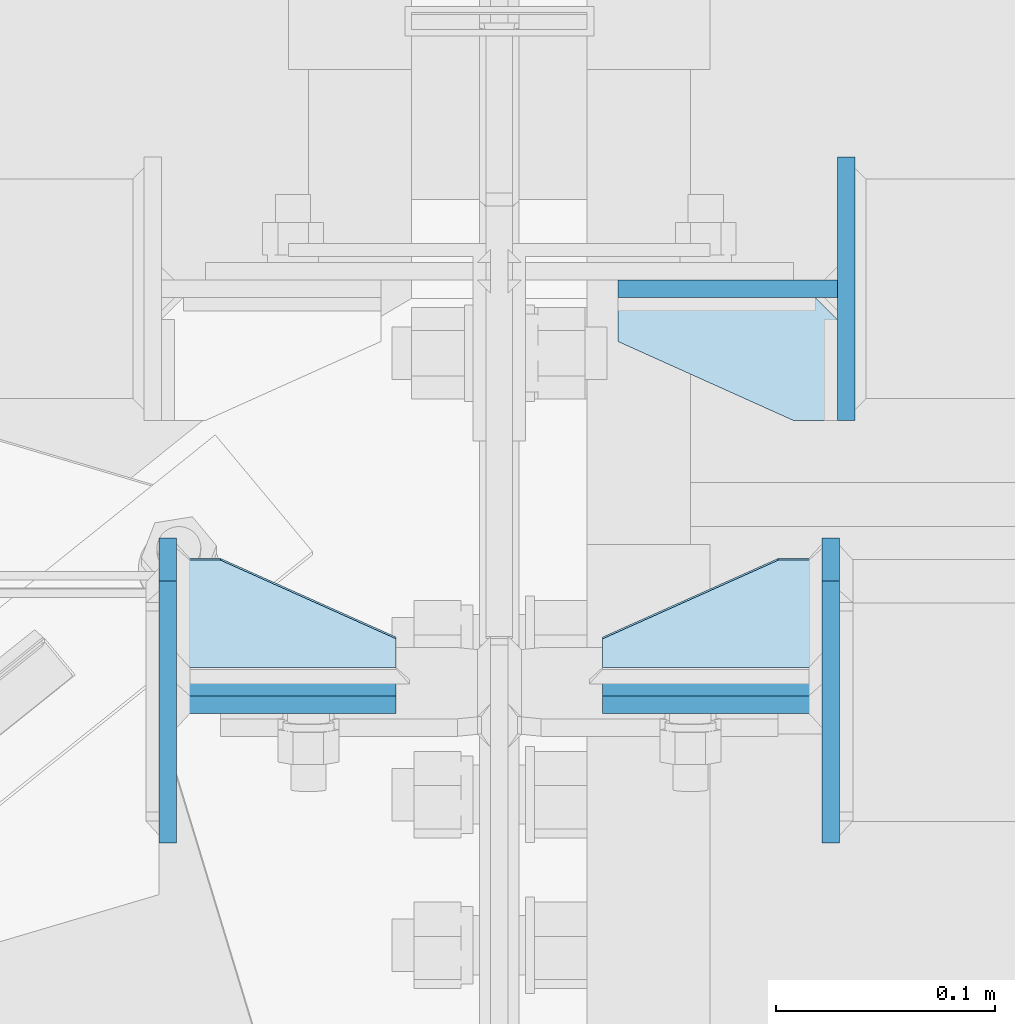
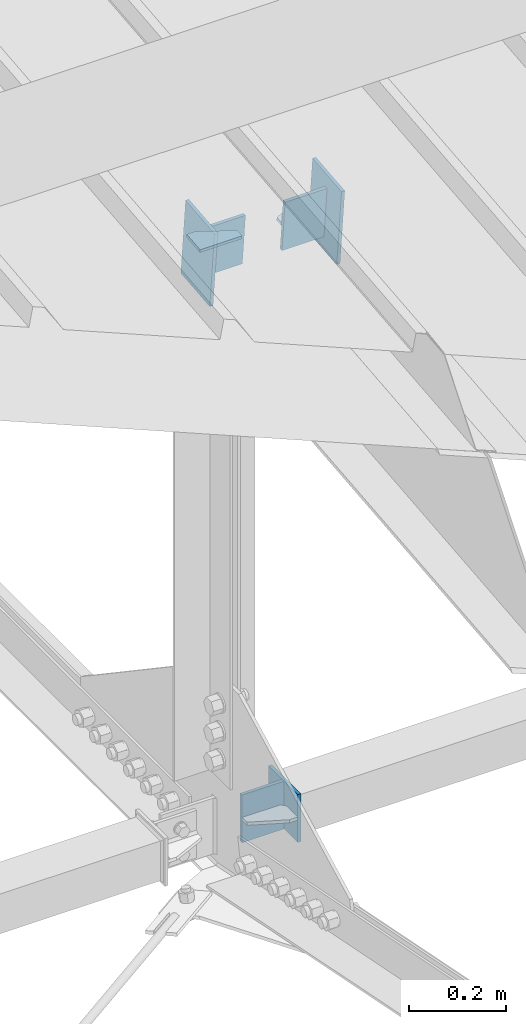
# One storey, part 114 of 709: 9 plates, 3 elements without a shape of their own.
"""IFC4 building model written with IfcOpenShell, lengths in millimetres."""

from ifc_helpers import new_model, si_unit, direction, frame, origin_with_axes, place, context, subcontext, project, spatial, line, indexed_curve, outline, extrude, material, element, aggregate, save


model = new_model("IFC4")

# Units and contexts
model_context = context("Model", 3, precision=0.2, world=origin_with_axes(), true_north=direction((0.0, 1.0)))
body_context = subcontext(model_context, "Body", "Model", "MODEL_VIEW")
ifc_project = project(units=[si_unit("LENGTHUNIT", "METRE", prefix="MILLI"), si_unit("AREAUNIT", "SQUARE_METRE"), si_unit("VOLUMEUNIT", "CUBIC_METRE"), si_unit("MASSUNIT", "GRAM", prefix="KILO"), si_unit("TIMEUNIT", "SECOND"), si_unit("PLANEANGLEUNIT", "RADIAN"), si_unit("SOLIDANGLEUNIT", "STERADIAN"), si_unit("THERMODYNAMICTEMPERATUREUNIT", "DEGREE_CELSIUS"), si_unit("LUMINOUSINTENSITYUNIT", "LUMEN")], contexts=[model_context])

# Site, building, storey
site_placement = place(None, origin_with_axes())
site = spatial("IfcSite", under=ifc_project, at=site_placement, CompositionType="ELEMENT")
building_placement = place(site_placement, origin_with_axes())
building = spatial("IfcBuilding", under=site, at=building_placement, Name="Undefined", CompositionType="ELEMENT")
storey_placement = place(building_placement, origin_with_axes())
storey = spatial("IfcBuildingStorey", under=building, at=storey_placement, Name="Undefined", CompositionType="ELEMENT", Elevation=0.0)

# Assembly, plates
assembly_1_placement = place(storey_placement, frame((10000.0, 5673.0, 6074.30002), z_axis=(0.0, -1.0, 0.0), x_axis=(1.0, 0.0, 0.0)))
assembly_1 = element("IfcElementAssembly", 1, at=assembly_1_placement, inside=storey)
ifc_material = material(Name="C355-6", Category="STEEL")
plate_1_placement = place(assembly_1_placement, frame((54.0, 0.0, 60.0), z_axis=(0.0, -1.0, 0.0), x_axis=(0.0, 0.0, -1.0)))
plate_1 = element("IfcPlate", 2, at=plate_1_placement, material=ifc_material, ObjectType="561", context=body_context, shape_type="SolidModel", body=[
    extrude(outline(indexed_curve([(0.0, 80.0), (36.0, 0.0), (56.0, 0.0), (56.0, 90.0), (46.0, 100.0), (0.0, 100.0)], segments=[line(1, 2, 3, 4, 5, 6, 1)])), frame((0.0, 0.0, 4.0), z_axis=(0.0, 0.0, 1.0), x_axis=(1.0, 0.0, 0.0)), (0.0, 0.0, -1.0), 8.0),
])
plate_2_placement = place(assembly_1_placement, frame((54.0, -60.0, 0.0), z_axis=(0.0, 0.0, -1.0), x_axis=(0.0, 1.0, 0.0)))
plate_2 = element("IfcPlate", 3, at=plate_2_placement, material=ifc_material, ObjectType="560", context=body_context, shape_type="SolidModel", body=[
    extrude(outline(indexed_curve([(0.0, 0.0), (120.0, 0.0), (120.0, 100.0), (0.0, 100.0)], segments=[line(1, 2, 3, 4, 1)])), frame((0.0, 0.0, 4.0), z_axis=(0.0, 0.0, 1.0), x_axis=(1.0, 0.0, 0.0)), (0.0, 0.0, -1.0), 8.0),
])
plate_3_placement = place(assembly_1_placement, frame((158.0, -60.0, -60.0), z_axis=(-1.0, 0.0, 0.0), x_axis=(0.0, 0.0, 1.0)))
plate_3 = element("IfcPlate", 4, at=plate_3_placement, material=ifc_material, ObjectType="559", context=body_context, shape_type="SolidModel", body=[
    extrude(outline(indexed_curve([(0.0, 0.0), (120.0, 0.0), (120.0, 120.0), (0.0, 120.0)], segments=[line(1, 2, 3, 4, 1)])), frame((0.0, 0.0, 4.0), z_axis=(0.0, 0.0, 1.0), x_axis=(1.0, 0.0, 0.0)), (0.0, 0.0, -1.0), 8.0),
])
aggregate(assembly_1, [plate_1, plate_2, plate_3])

assembly_2_placement = place(storey_placement, frame((4000.0, 5490.04963, 7677.46908), z_axis=(0.0, 0.9950371902, 0.099503719), x_axis=(1.0, 0.0, 0.0)))
assembly_2 = element("IfcElementAssembly", 5, at=assembly_2_placement, inside=storey)
plate_4_placement = place(assembly_2_placement, frame((5953.0, 0.0, 60.0), z_axis=(0.0, -1.0, 0.0), x_axis=(-1.0, 0.0, 0.0)))
plate_4 = element("IfcPlate", 6, at=plate_4_placement, material=ifc_material, ObjectType="588", context=body_context, shape_type="SolidModel", body=[
    extrude(outline(indexed_curve([(0.0, 36.0), (80.0, 0.0), (100.0, 0.0), (100.0, 56.0), (0.0, 56.0)], segments=[line(1, 2, 3, 4, 5, 1)])), frame((0.0, 0.0, 4.0), z_axis=(0.0, 0.0, 1.0), x_axis=(1.0, 0.0, 0.0)), (0.0, 0.0, -1.0), 8.0),
])
plate_5_placement = place(assembly_2_placement, frame((5849.0, -98.0, 60.0), z_axis=(1.0, 0.0, 0.0), x_axis=(0.0, 0.0, -1.0)))
plate_5 = element("IfcPlate", 7, at=plate_5_placement, material=ifc_material, ObjectType="586", context=body_context, shape_type="SolidModel", body=[
    extrude(outline(indexed_curve([(0.0, 0.0), (120.0, 0.0), (120.0, 196.0), (0.0, 196.0)], segments=[line(1, 2, 3, 4, 1)])), frame((0.0, 0.0, 4.0), z_axis=(0.0, 0.0, 1.0), x_axis=(1.0, 0.0, 0.0)), (0.0, 0.0, -1.0), 8.0),
])
plate_6_placement = place(assembly_2_placement, frame((5953.0, 65.0, 0.0), z_axis=(0.0, 0.0, 1.0), x_axis=(-1.0, 0.0, 0.0)))
plate_6 = element("IfcPlate", 8, at=plate_6_placement, material=ifc_material, ObjectType="587", context=body_context, shape_type="SolidModel", body=[
    extrude(outline(indexed_curve([(0.0, 0.0), (100.0, 0.0), (100.0, 130.0), (0.0, 130.0)], segments=[line(1, 2, 3, 4, 1)])), frame((0.0, 0.0, 4.0), z_axis=(0.0, 0.0, 1.0), x_axis=(1.0, 0.0, 0.0)), (0.0, 0.0, -1.0), 8.0),
])
aggregate(assembly_2, [plate_4, plate_5, plate_6])

assembly_3_placement = place(storey_placement, frame((10000.0, 5490.04963, 7677.46908), z_axis=(0.0, 0.9950371902, 0.099503719), x_axis=(1.0, 0.0, 0.0)))
assembly_3 = element("IfcElementAssembly", 9, at=assembly_3_placement, inside=storey)
plate_7_placement = place(assembly_3_placement, frame((151.0, -98.0, -60.0), z_axis=(-1.0, 0.0, 0.0), x_axis=(0.0, 0.0, 1.0)))
plate_7 = element("IfcPlate", 10, at=plate_7_placement, material=ifc_material, ObjectType="586", context=body_context, shape_type="SolidModel", body=[
    extrude(outline(indexed_curve([(0.0, 0.0), (120.0, 0.0), (120.0, 196.0), (0.0, 196.0)], segments=[line(1, 2, 3, 4, 1)])), frame((0.0, 0.0, 4.0), z_axis=(0.0, 0.0, 1.0), x_axis=(1.0, 0.0, 0.0)), (0.0, 0.0, -1.0), 8.0),
])
plate_8_placement = place(assembly_3_placement, frame((47.0, 0.0, 60.0), z_axis=(0.0, 1.0, 0.0), x_axis=(1.0, 0.0, 0.0)))
plate_8 = element("IfcPlate", 11, at=plate_8_placement, material=ifc_material, ObjectType="588", context=body_context, shape_type="SolidModel", body=[
    extrude(outline(indexed_curve([(0.0, 36.0), (80.0, 0.0), (100.0, 0.0), (100.0, 56.0), (0.0, 56.0)], segments=[line(1, 2, 3, 4, 5, 1)])), frame((0.0, 0.0, 4.0), z_axis=(0.0, 0.0, 1.0), x_axis=(1.0, 0.0, 0.0)), (0.0, 0.0, -1.0), 8.0),
])
plate_9_placement = place(assembly_3_placement, frame((47.0, -65.0, 0.0), z_axis=(0.0, 0.0, 1.0), x_axis=(1.0, 0.0, 0.0)))
plate_9 = element("IfcPlate", 12, at=plate_9_placement, material=ifc_material, ObjectType="587", context=body_context, shape_type="SolidModel", body=[
    extrude(outline(indexed_curve([(0.0, 0.0), (100.0, 0.0), (100.0, 130.0), (0.0, 130.0)], segments=[line(1, 2, 3, 4, 1)])), frame((0.0, 0.0, 4.0), z_axis=(0.0, 0.0, 1.0), x_axis=(1.0, 0.0, 0.0)), (0.0, 0.0, -1.0), 8.0),
])
aggregate(assembly_3, [plate_7, plate_8, plate_9])

save(model, "model.ifc")
